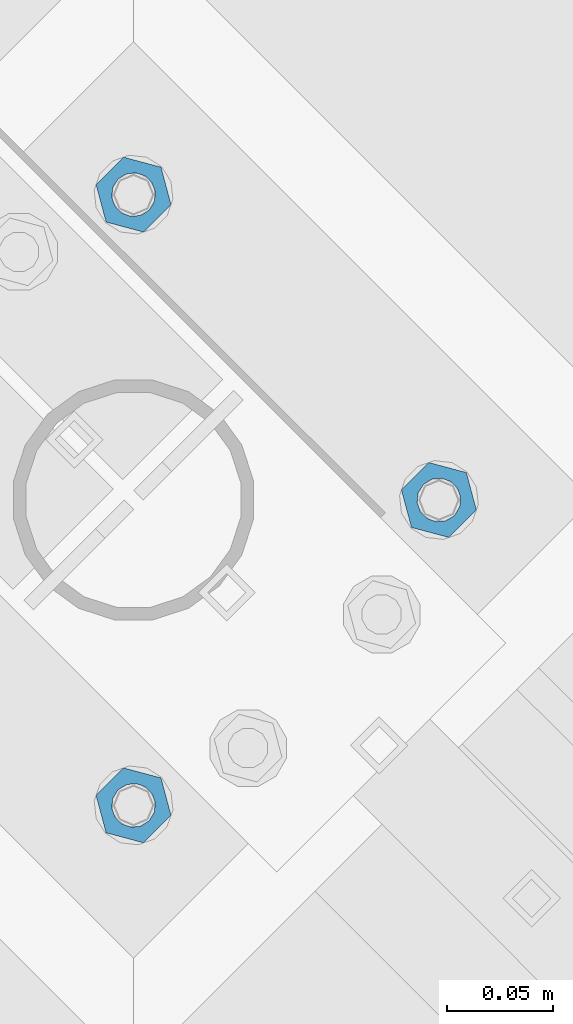
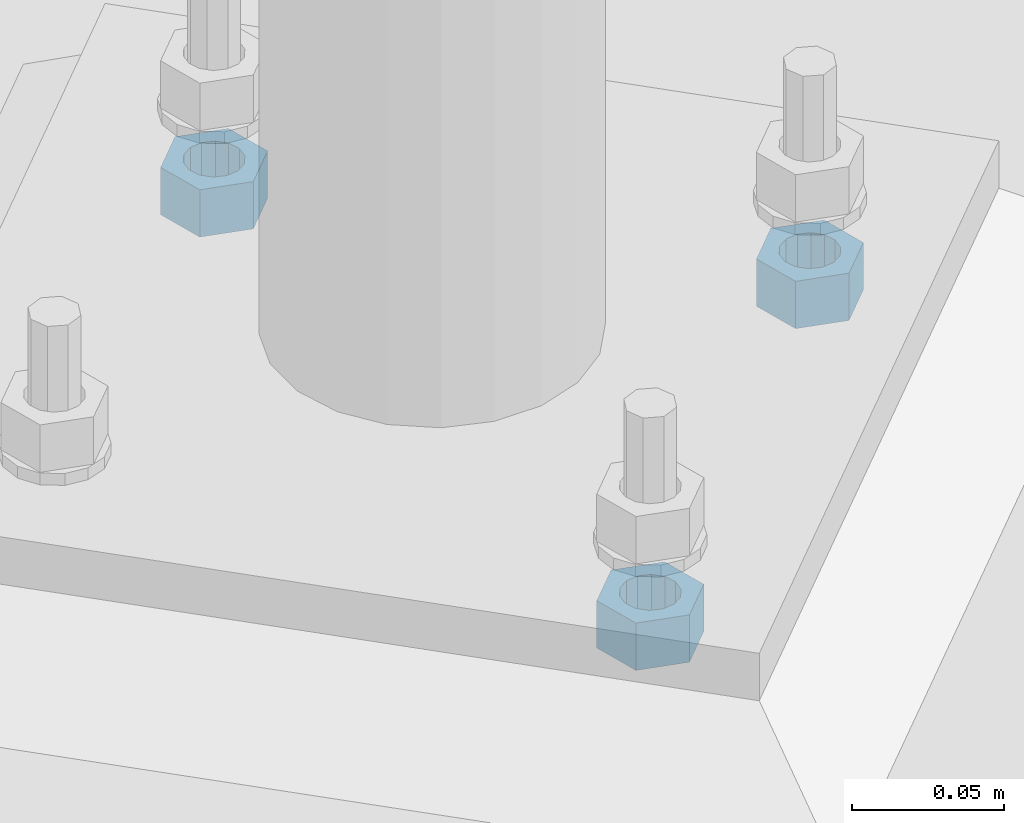
# One storey, part 636 of 975: 3 beams.
"""IFC2X3 building model written with IfcOpenShell, lengths in millimetres."""

import ifcopenshell
import ifcopenshell.guid

model = None  # the IFC model being written
_history = None  # IfcOwnerHistory: only IFC2X3 demands one
_inside = {}  # id of a spatial element -> (the spatial element, [elements in it])
_under = {}  # id of a project, library or spatial element -> (it, [spatial elements below it])
_declared = {}  # id of a project -> (the project, [libraries it declares])
_typed = {}  # id of a type object -> (the type object, [elements of that type])
_made_of = {}  # id of a material, layer set ... -> (it, [elements and type objects made of it])


def new_model(schema):
    """Start an empty IFC model of exactly this schema.

    Asked for "IFC4X3", IfcOpenShell would pick the latest addendum, in which some entities
    have other attributes; the version numbers below select the first issue.
    IFC2X3 requires an IfcOwnerHistory on every rooted entity: one is made here for all.
    """
    global model, _history
    if schema == "IFC4X3":
        model = ifcopenshell.file(schema_version=(4, 3, 0, 0))
    else:
        model = ifcopenshell.file(schema=schema)
    _inside.clear()
    _under.clear()
    _declared.clear()
    _typed.clear()
    _made_of.clear()
    _history = None
    if model.schema == "IFC2X3":
        org = make("IfcOrganization", Name="unknown")
        user = make(
            "IfcPersonAndOrganization",
            ThePerson=make("IfcPerson", FamilyName="unknown"),
            TheOrganization=org,
        )
        app = make(
            "IfcApplication",
            ApplicationDeveloper=org,
            Version="unknown",
            ApplicationFullName="unknown",
            ApplicationIdentifier="unknown",
        )
        _history = make(
            "IfcOwnerHistory",
            OwningUser=user,
            OwningApplication=app,
            ChangeAction="ADDED",
            CreationDate=0,
        )
    return model


def make(cls, **values):
    """One entity of the class cls with the attributes given. An attribute that is None is left unset."""
    return model.create_entity(
        cls, **{name: value for name, value in values.items() if value is not None}
    )


def rooted(cls, **values):
    """An entity with a GlobalId (a new one), such as an element, a storey or a relation."""
    return make(cls, GlobalId=ifcopenshell.guid.new(), OwnerHistory=_history, **values)


def si_unit(unit_type, name, prefix=None):
    """IfcSIUnit, for example si_unit("LENGTHUNIT", "METRE", prefix="MILLI")."""
    return make("IfcSIUnit", UnitType=unit_type, Prefix=prefix, Name=name)


def assignment(units):
    """IfcUnitAssignment: the units of a project."""
    return None if units is None else make("IfcUnitAssignment", Units=units)


def point(xyz):
    """IfcCartesianPoint."""
    return None if xyz is None else make("IfcCartesianPoint", Coordinates=xyz)


def direction(xyz):
    """IfcDirection."""
    return None if xyz is None else make("IfcDirection", DirectionRatios=xyz)


def frame(location, z_axis=None, x_axis=None):
    """IfcAxis2Placement3D, a coordinate frame: its origin and axes. An axis left out is left unset."""
    return make(
        "IfcAxis2Placement3D",
        Location=point(location),
        Axis=direction(z_axis),
        RefDirection=direction(x_axis),
    )


def origin_with_axes():
    """The frame at (0, 0, 0) with the z axis (0, 0, 1) and the x axis (1, 0, 0) written out."""
    return frame((0.0, 0.0, 0.0), z_axis=(0.0, 0.0, 1.0), x_axis=(1.0, 0.0, 0.0))


def place(relative_to, where):
    """IfcLocalPlacement: puts the frame where relative to a parent placement (None: the world)."""
    return make(
        "IfcLocalPlacement", PlacementRelTo=relative_to, RelativePlacement=where
    )


def context(
    kind, dimensions, precision=None, world=None, true_north=None, identifier=None
):
    """IfcGeometricRepresentationContext, for example the 3D "Model" context."""
    return make(
        "IfcGeometricRepresentationContext",
        ContextIdentifier=identifier,
        ContextType=kind,
        CoordinateSpaceDimension=dimensions,
        Precision=precision,
        WorldCoordinateSystem=world,
        TrueNorth=true_north,
    )


def subcontext(parent, identifier, kind, view, scale=None):
    """IfcGeometricRepresentationSubContext, for example "Body" below "Model"."""
    return make(
        "IfcGeometricRepresentationSubContext",
        ContextIdentifier=identifier,
        ContextType=kind,
        ParentContext=parent,
        TargetScale=scale,
        TargetView=view,
    )


def project(units=None, contexts=None):
    """IfcProject with its units and contexts."""
    return rooted(
        "IfcProject",
        Name="project",
        RepresentationContexts=contexts,
        UnitsInContext=assignment(units),
    )


def spatial(cls, under=None, at=None, **own):
    """A site, building, storey or space (cls), placed at a placement, below another one or the project."""
    s = rooted(cls, ObjectPlacement=at, **own)
    if under is not None:
        _under.setdefault(under.id(), (under, []))[1].append(s)
    return s


def faces_of(points, faces, orient=None, outer=None):
    """IfcFace entities. A face is a list of loops; a loop is a list of indices into points, from 0.

    orient and outer hold one flag for each loop. By default every Orientation is true, the
    first loop of a face is its IfcFaceOuterBound and the others are IfcFaceBound.
    """
    made = []
    for i, loops in enumerate(faces):
        bounds = []
        for j, loop in enumerate(loops):
            is_outer = j == 0 if outer is None else outer[i][j]
            bounds.append(
                make(
                    "IfcFaceOuterBound" if is_outer else "IfcFaceBound",
                    Bound=make("IfcPolyLoop", Polygon=[points[k] for k in loop]),
                    Orientation=True if orient is None else orient[i][j],
                )
            )
        made.append(make("IfcFace", Bounds=bounds))
    return made


def faceted_brep(points, faces, orient=None, outer=None, voids=None):
    """IfcFacetedBrep: a solid bounded by flat faces; with voids (closed shells), ...WithVoids."""
    shared = [point(p) for p in points]
    hull = make("IfcClosedShell", CfsFaces=faces_of(shared, faces, orient, outer))
    if voids is None:
        return make("IfcFacetedBrep", Outer=hull)
    return make(
        "IfcFacetedBrepWithVoids",
        Outer=hull,
        Voids=[
            make(cls, CfsFaces=faces_of(shared, fs, o, b)) for cls, fs, o, b in voids
        ],
    )


def shape(context_of_items, identifier, shape_type, items):
    """IfcShapeRepresentation: the items that make up one representation, for example the "Body"."""
    return make(
        "IfcShapeRepresentation",
        ContextOfItems=context_of_items,
        RepresentationIdentifier=identifier,
        RepresentationType=shape_type,
        Items=items,
    )


def material(Name=None, Category=None):
    """IfcMaterial."""
    return make("IfcMaterial", Name=Name, Category=Category)


def made_of(thing, what):
    """Note that an element or type object is made of a material, layer set ...; save() writes the relation."""
    if what is not None:
        _made_of.setdefault(what.id(), (what, []))[1].append(thing)
    return thing


def type_object(cls, material=None, **own):
    """A type object (cls), such as IfcWallType, which elements share."""
    return made_of(rooted(cls, **own), material)


def element(
    cls,
    number,
    at=None,
    inside=None,
    cuts=None,
    type_object=None,
    material=None,
    context=None,
    identifier="Body",
    shape_type=None,
    held_by="IfcProductDefinitionShape",
    body=None,
    shapes=None,
    **own,
):
    """One element of the class cls, such as IfcWall. Its Tag is "e" and its number.

    at: its placement. inside: the storey or other place that contains it. cuts: it is an
    opening in that element (IfcRelVoidsElement). A single representation is given by context,
    identifier, shape_type and body (its items); several are given by shapes. held_by: the class
    of the entity that holds the representations. save() writes the other relations.
    """
    e = rooted(cls, Tag="e%d" % number, ObjectPlacement=at, **own)
    if body is not None:
        shapes = [shape(context, identifier, shape_type, body)]
    if shapes is not None:
        e.Representation = make(held_by, Representations=shapes)
    if inside is not None:
        _inside.setdefault(inside.id(), (inside, []))[1].append(e)
    if cuts is not None:
        rooted(
            "IfcRelVoidsElement", RelatingBuildingElement=cuts, RelatedOpeningElement=e
        )
    if type_object is not None:
        _typed.setdefault(type_object.id(), (type_object, []))[1].append(e)
    return made_of(e, material)


def aggregate(whole, parts):
    """IfcRelAggregates: a whole, such as a stair, and the parts it consists of."""
    return rooted("IfcRelAggregates", RelatingObject=whole, RelatedObjects=parts)


def save(model, path):
    """Write the relations noted so far, then the file.

    IfcRelAggregates (storeys below a building ...), IfcRelContainedInSpatialStructure (elements
    in a storey), IfcRelDefinesByType, IfcRelAssociatesMaterial and IfcRelDeclares: one each for
    every whole, place, type object, material and project.
    """
    for whole, parts in _under.values():
        aggregate(whole, parts)
    for where, things in _inside.values():
        rooted(
            "IfcRelContainedInSpatialStructure",
            RelatedElements=things,
            RelatingStructure=where,
        )
    for kind, things in _typed.values():
        rooted("IfcRelDefinesByType", RelatedObjects=things, RelatingType=kind)
    for what, things in _made_of.values():
        rooted("IfcRelAssociatesMaterial", RelatedObjects=things, RelatingMaterial=what)
    for by, libraries in _declared.values():
        rooted("IfcRelDeclares", RelatingContext=by, RelatedDefinitions=libraries)
    model.write(path)


model = new_model("IFC2X3")

# Units and contexts
model_context = context("Model", 3, precision=1e-05, world=origin_with_axes())
body_context = subcontext(model_context, "Body", "Model", "MODEL_VIEW")
ifc_project = project(units=[si_unit("LENGTHUNIT", "METRE", prefix="MILLI"), si_unit("AREAUNIT", "SQUARE_METRE"), si_unit("VOLUMEUNIT", "CUBIC_METRE"), si_unit("MASSUNIT", "GRAM", prefix="KILO"), si_unit("TIMEUNIT", "SECOND"), si_unit("PLANEANGLEUNIT", "RADIAN"), si_unit("SOLIDANGLEUNIT", "STERADIAN"), si_unit("THERMODYNAMICTEMPERATUREUNIT", "DEGREE_CELSIUS"), si_unit("LUMINOUSINTENSITYUNIT", "LUMEN")], contexts=[model_context])

# Site, building, storey
site_placement = place(None, origin_with_axes())
site = spatial("IfcSite", under=ifc_project, at=site_placement, CompositionType="ELEMENT")
building_placement = place(site_placement, origin_with_axes())
building = spatial("IfcBuilding", under=site, at=building_placement, Name="Undefined", CompositionType="ELEMENT")
storey_placement = place(building_placement, origin_with_axes())
storey = spatial("IfcBuildingStorey", under=building, at=storey_placement, Name="Undefined", CompositionType="ELEMENT", Elevation=0.0)

# Beams
ifc_material = material(Name="STEEL/A36")
beam_type = type_object("IfcBeamType", Name="3/4_HEAVY_HEX_NUT", PredefinedType="NOTDEFINED")
beam_1_placement = place(storey_placement, frame((20731.162498921, 27759.8034053001, -266.7), z_axis=(0.707106781186513, -0.707106781186582, 3.1377567211166e-14), x_axis=(0.0, 0.0, -1.0)))
element("IfcBeam", 1, at=beam_1_placement, inside=storey, type_object=beam_type, material=ifc_material, Name="NUT", ObjectType="3/4_HEAVY_HEX_NUT", context=body_context, shape_type="Brep", body=[
    faceted_brep([(0.0, -18.2600002288818, 0.0), (0.0, -9.13000011444092, -15.8100004196167), (19.0499999999993, -9.13000011444092, -15.8100004196167), (19.0499999999993, -18.2600002288818, 0.0), (0.0, 9.13000011444092, -15.8100004196167), (19.0499999999993, 9.13000011444092, -15.8100004196167), (0.0, 18.2600002288818, 0.0), (19.0499999999993, 18.2600002288818, 0.0), (0.0, 9.13000011444092, 15.8100004196167), (19.0499999999993, 9.13000011444092, 15.8100004196167), (0.0, -9.13000011444092, 15.8100004196167), (19.0499999999993, -9.13000011444092, 15.8100004196167), (0.0, 0.0, 10.3199996948242), (0.0, 4.47768005528269, 9.29799844179911), (19.0499999999993, 4.47768005528269, 9.29799844179911), (19.0499999999993, 0.0, 10.3199996948242), (0.0, 8.06850066047446, 6.43441456490817), (19.0499999999993, 8.06850066047446, 6.43441456490817), (0.0, 10.0612557561917, 2.29641597052117), (19.0499999999993, 10.0612557561917, 2.29641597052117), (0.0, 10.0612557561917, -2.29641597052117), (19.0499999999993, 10.0612557561917, -2.29641597052117), (0.0, 8.06850066047446, -6.43441456490814), (19.0499999999993, 8.06850066047446, -6.43441456490814), (0.0, 4.47768005528269, -9.29799844179908), (19.0499999999993, 4.47768005528269, -9.29799844179908), (0.0, 0.0, -10.3199996948242), (19.0499999999993, 0.0, -10.3199996948242), (0.0, -4.47768005528269, -9.29799844179911), (19.0499999999993, -4.47768005528269, -9.29799844179911), (0.0, -8.06850066047446, -6.43441456490817), (19.0499999999993, -8.06850066047446, -6.43441456490817), (0.0, -10.0612557561917, -2.29641597052117), (19.0499999999993, -10.0612557561917, -2.29641597052117), (0.0, -10.0612557561917, 2.29641597052117), (19.0499999999993, -10.0612557561917, 2.29641597052117), (0.0, -8.06850066047446, 6.43441456490814), (19.0499999999993, -8.06850066047446, 6.43441456490814), (0.0, -4.47768005528269, 9.29799844179908), (19.0499999999993, -4.47768005528269, 9.29799844179908)], [[[0, 1, 2, 3]], [[1, 4, 5, 2]], [[4, 6, 7, 5]], [[6, 8, 9, 7]], [[8, 10, 11, 9]], [[10, 0, 3, 11]], [[12, 13, 14, 15]], [[13, 16, 17, 14]], [[16, 18, 19, 17]], [[18, 20, 21, 19]], [[20, 22, 23, 21]], [[22, 24, 25, 23]], [[24, 26, 27, 25]], [[26, 28, 29, 27]], [[28, 30, 31, 29]], [[30, 32, 33, 31]], [[32, 34, 35, 33]], [[34, 36, 37, 35]], [[36, 38, 39, 37]], [[38, 12, 15, 39]], [[5, 7, 9, 11, 3, 2], [17, 19, 21, 23, 25, 27, 29, 31, 33, 35, 37, 39, 15, 14]], [[10, 8, 6, 4, 1, 0], [38, 36, 34, 32, 30, 28, 26, 24, 22, 20, 18, 16, 13, 12]]]),
])
beam_2_placement = place(storey_placement, frame((20874.8465946999, 27903.487501079, -266.7), z_axis=(-0.707106781186601, 0.707106781186494, 2.36468622460961e-14), x_axis=(0.0, 0.0, -1.0)))
element("IfcBeam", 2, at=beam_2_placement, inside=storey, type_object=beam_type, material=ifc_material, Name="NUT", ObjectType="3/4_HEAVY_HEX_NUT", context=body_context, shape_type="Brep", body=[
    faceted_brep([(0.0, -18.2600002288818, 0.0), (0.0, -9.13000011444092, -15.8100004196167), (19.0499999999993, -9.13000011444092, -15.8100004196167), (19.0499999999993, -18.2600002288818, 0.0), (0.0, 9.13000011444092, -15.8100004196167), (19.0499999999993, 9.13000011444092, -15.8100004196167), (0.0, 18.2600002288818, 0.0), (19.0499999999993, 18.2600002288818, 0.0), (0.0, 9.13000011444092, 15.8100004196167), (19.0499999999993, 9.13000011444092, 15.8100004196167), (0.0, -9.13000011444092, 15.8100004196167), (19.0499999999993, -9.13000011444092, 15.8100004196167), (0.0, 0.0, 10.3199996948242), (0.0, 4.47768005528269, 9.29799844179911), (19.0499999999993, 4.47768005528269, 9.29799844179911), (19.0499999999993, 0.0, 10.3199996948242), (0.0, 8.06850066047446, 6.43441456490817), (19.0499999999993, 8.06850066047446, 6.43441456490817), (0.0, 10.0612557561917, 2.29641597052117), (19.0499999999993, 10.0612557561917, 2.29641597052117), (0.0, 10.0612557561917, -2.29641597052117), (19.0499999999993, 10.0612557561917, -2.29641597052117), (0.0, 8.06850066047446, -6.43441456490814), (19.0499999999993, 8.06850066047446, -6.43441456490814), (0.0, 4.47768005528269, -9.29799844179908), (19.0499999999993, 4.47768005528269, -9.29799844179908), (0.0, 0.0, -10.3199996948242), (19.0499999999993, 0.0, -10.3199996948242), (0.0, -4.47768005528269, -9.29799844179911), (19.0499999999993, -4.47768005528269, -9.29799844179911), (0.0, -8.06850066047446, -6.43441456490817), (19.0499999999993, -8.06850066047446, -6.43441456490817), (0.0, -10.0612557561917, -2.29641597052117), (19.0499999999993, -10.0612557561917, -2.29641597052117), (0.0, -10.0612557561917, 2.29641597052117), (19.0499999999993, -10.0612557561917, 2.29641597052117), (0.0, -8.06850066047446, 6.43441456490814), (19.0499999999993, -8.06850066047446, 6.43441456490814), (0.0, -4.47768005528269, 9.29799844179908), (19.0499999999993, -4.47768005528269, 9.29799844179908)], [[[0, 1, 2, 3]], [[1, 4, 5, 2]], [[4, 6, 7, 5]], [[6, 8, 9, 7]], [[8, 10, 11, 9]], [[10, 0, 3, 11]], [[12, 13, 14, 15]], [[13, 16, 17, 14]], [[16, 18, 19, 17]], [[18, 20, 21, 19]], [[20, 22, 23, 21]], [[22, 24, 25, 23]], [[24, 26, 27, 25]], [[26, 28, 29, 27]], [[28, 30, 31, 29]], [[30, 32, 33, 31]], [[32, 34, 35, 33]], [[34, 36, 37, 35]], [[36, 38, 39, 37]], [[38, 12, 15, 39]], [[5, 7, 9, 11, 3, 2], [17, 19, 21, 23, 25, 27, 29, 31, 33, 35, 37, 39, 15, 14]], [[10, 8, 6, 4, 1, 0], [38, 36, 34, 32, 30, 28, 26, 24, 22, 20, 18, 16, 13, 12]]]),
])
beam_3_placement = place(storey_placement, frame((20731.162498921, 28047.1715968578, -266.7), z_axis=(-0.707106781186601, 0.707106781186494, 2.36468622460961e-14), x_axis=(0.0, 0.0, -1.0)))
element("IfcBeam", 3, at=beam_3_placement, inside=storey, type_object=beam_type, material=ifc_material, Name="NUT", ObjectType="3/4_HEAVY_HEX_NUT", context=body_context, shape_type="Brep", body=[
    faceted_brep([(0.0, -18.2600002288818, 0.0), (0.0, -9.13000011444092, -15.8100004196167), (19.0499999999993, -9.13000011444092, -15.8100004196167), (19.0499999999993, -18.2600002288818, 0.0), (0.0, 9.13000011444092, -15.8100004196167), (19.0499999999993, 9.13000011444092, -15.8100004196167), (0.0, 18.2600002288818, 0.0), (19.0499999999993, 18.2600002288818, 0.0), (0.0, 9.13000011444092, 15.8100004196167), (19.0499999999993, 9.13000011444092, 15.8100004196167), (0.0, -9.13000011444092, 15.8100004196167), (19.0499999999993, -9.13000011444092, 15.8100004196167), (0.0, 0.0, 10.3199996948242), (0.0, 4.47768005528269, 9.29799844179911), (19.0499999999993, 4.47768005528269, 9.29799844179911), (19.0499999999993, 0.0, 10.3199996948242), (0.0, 8.06850066047446, 6.43441456490817), (19.0499999999993, 8.06850066047446, 6.43441456490817), (0.0, 10.0612557561917, 2.29641597052117), (19.0499999999993, 10.0612557561917, 2.29641597052117), (0.0, 10.0612557561917, -2.29641597052117), (19.0499999999993, 10.0612557561917, -2.29641597052117), (0.0, 8.06850066047446, -6.43441456490814), (19.0499999999993, 8.06850066047446, -6.43441456490814), (0.0, 4.47768005528269, -9.29799844179908), (19.0499999999993, 4.47768005528269, -9.29799844179908), (0.0, 0.0, -10.3199996948242), (19.0499999999993, 0.0, -10.3199996948242), (0.0, -4.47768005528269, -9.29799844179911), (19.0499999999993, -4.47768005528269, -9.29799844179911), (0.0, -8.06850066047446, -6.43441456490817), (19.0499999999993, -8.06850066047446, -6.43441456490817), (0.0, -10.0612557561917, -2.29641597052117), (19.0499999999993, -10.0612557561917, -2.29641597052117), (0.0, -10.0612557561917, 2.29641597052117), (19.0499999999993, -10.0612557561917, 2.29641597052117), (0.0, -8.06850066047446, 6.43441456490814), (19.0499999999993, -8.06850066047446, 6.43441456490814), (0.0, -4.47768005528269, 9.29799844179908), (19.0499999999993, -4.47768005528269, 9.29799844179908)], [[[0, 1, 2, 3]], [[1, 4, 5, 2]], [[4, 6, 7, 5]], [[6, 8, 9, 7]], [[8, 10, 11, 9]], [[10, 0, 3, 11]], [[12, 13, 14, 15]], [[13, 16, 17, 14]], [[16, 18, 19, 17]], [[18, 20, 21, 19]], [[20, 22, 23, 21]], [[22, 24, 25, 23]], [[24, 26, 27, 25]], [[26, 28, 29, 27]], [[28, 30, 31, 29]], [[30, 32, 33, 31]], [[32, 34, 35, 33]], [[34, 36, 37, 35]], [[36, 38, 39, 37]], [[38, 12, 15, 39]], [[5, 7, 9, 11, 3, 2], [17, 19, 21, 23, 25, 27, 29, 31, 33, 35, 37, 39, 15, 14]], [[10, 8, 6, 4, 1, 0], [38, 36, 34, 32, 30, 28, 26, 24, 22, 20, 18, 16, 13, 12]]]),
])

save(model, "model.ifc")
